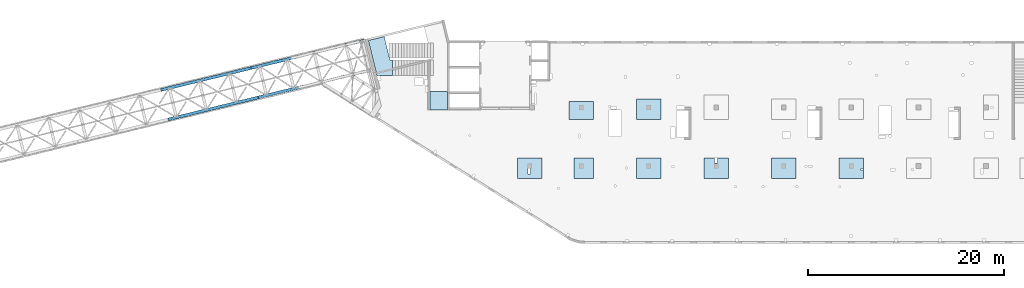
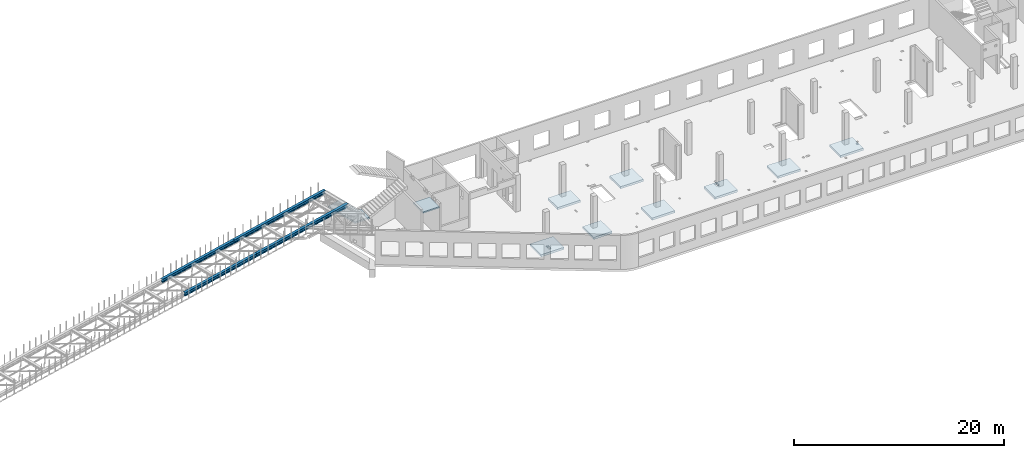
# One storey, part 13 of 66: 10 slabs, 4 beams.
"""IFC4 building model written with IfcOpenShell, lengths in millimetres."""

from ifc_helpers import new_model, entity, si_unit, converted_unit, derived_unit, direction, frame, origin, place, context, subcontext, project, spatial, indexed_curve, outline, extrude, material, type_object, element, save


model = new_model("IFC4")

# Units and contexts
model_context = context("Model", 3, precision=0.01, world=origin(), true_north=direction((6.12303176911189e-17, 1.0)))
plan_context = context("Plan", 3, precision=0.01, world=origin(), true_north=direction((6.12303176911189e-17, 1.0)))
body_context = subcontext(model_context, "Body", "Model", "MODEL_VIEW")
ifc_project = project(units=[si_unit("LENGTHUNIT", "METRE", prefix="MILLI"), si_unit("AREAUNIT", "SQUARE_METRE"), si_unit("VOLUMEUNIT", "CUBIC_METRE"), converted_unit("PLANEANGLEUNIT", "DEGREE", entity("IfcRatioMeasure", 0.0174532925199433), si_unit("PLANEANGLEUNIT", "RADIAN"), dimensions=[0, 0, 0, 0, 0, 0, 0]), si_unit("MASSUNIT", "GRAM", prefix="KILO"), derived_unit("MASSDENSITYUNIT", [(si_unit("MASSUNIT", "GRAM", prefix="KILO"), 1), (si_unit("LENGTHUNIT", "METRE"), -3)]), derived_unit("MOMENTOFINERTIAUNIT", [(si_unit("LENGTHUNIT", "METRE"), 4)]), si_unit("TIMEUNIT", "SECOND"), si_unit("FREQUENCYUNIT", "HERTZ"), si_unit("THERMODYNAMICTEMPERATUREUNIT", "DEGREE_CELSIUS"), derived_unit("THERMALTRANSMITTANCEUNIT", [(si_unit("MASSUNIT", "GRAM", prefix="KILO"), 1), (si_unit("THERMODYNAMICTEMPERATUREUNIT", "KELVIN"), -1), (si_unit("TIMEUNIT", "SECOND"), -3)]), derived_unit("VOLUMETRICFLOWRATEUNIT", [(si_unit("LENGTHUNIT", "METRE"), 3), (si_unit("TIMEUNIT", "SECOND"), -1)]), derived_unit("MASSFLOWRATEUNIT", [(si_unit("MASSUNIT", "GRAM", prefix="KILO"), 1), (si_unit("TIMEUNIT", "SECOND"), -1)]), derived_unit("ROTATIONALFREQUENCYUNIT", [(si_unit("TIMEUNIT", "SECOND"), -1)]), si_unit("ELECTRICCURRENTUNIT", "AMPERE"), si_unit("ELECTRICVOLTAGEUNIT", "VOLT"), si_unit("POWERUNIT", "WATT"), si_unit("FORCEUNIT", "NEWTON", prefix="KILO"), si_unit("ILLUMINANCEUNIT", "LUX"), si_unit("LUMINOUSFLUXUNIT", "LUMEN"), si_unit("LUMINOUSINTENSITYUNIT", "CANDELA"), derived_unit("USERDEFINED", [(si_unit("MASSUNIT", "GRAM", prefix="KILO"), -1), (si_unit("LENGTHUNIT", "METRE"), -2), (si_unit("TIMEUNIT", "SECOND"), 3), (si_unit("LUMINOUSFLUXUNIT", "LUMEN"), 1)]), derived_unit("LINEARVELOCITYUNIT", [(si_unit("LENGTHUNIT", "METRE"), 1), (si_unit("TIMEUNIT", "SECOND"), -1)]), si_unit("PRESSUREUNIT", "PASCAL"), derived_unit("USERDEFINED", [(si_unit("LENGTHUNIT", "METRE"), -2), (si_unit("MASSUNIT", "GRAM", prefix="KILO"), 1), (si_unit("TIMEUNIT", "SECOND"), -2)]), derived_unit("LINEARFORCEUNIT", [(si_unit("MASSUNIT", "GRAM", prefix="KILO"), 1), (si_unit("LENGTHUNIT", "METRE"), 1), (si_unit("TIMEUNIT", "SECOND"), -2), (si_unit("LENGTHUNIT", "METRE"), -1)]), derived_unit("PLANARFORCEUNIT", [(si_unit("MASSUNIT", "GRAM", prefix="KILO"), 1), (si_unit("LENGTHUNIT", "METRE"), 1), (si_unit("TIMEUNIT", "SECOND"), -2), (si_unit("LENGTHUNIT", "METRE"), -2)])], contexts=[model_context, plan_context])

# Site, building, storey
site_placement = place(None, origin())
site = spatial("IfcSite", under=ifc_project, at=site_placement, CompositionType="ELEMENT")
building_placement = place(site_placement, origin())
building = spatial("IfcBuilding", under=site, at=building_placement, CompositionType="ELEMENT")
storey_placement = place(building_placement, frame((0.0, 0.0, 19800.0)))
storey = spatial("IfcBuildingStorey", under=building, at=storey_placement, Name="06", CompositionType="ELEMENT", Elevation=19800.0)

# Beams
ifc_material_1 = material(Name="Metal painted (White)")
beam_type = type_object("IfcBeamType", PredefinedType="BEAM")
placement = place(storey_placement, origin())
element("IfcBeam", 1, at=placement, inside=storey, type_object=beam_type, material=ifc_material_1, ObjectType="Steel Beam", PredefinedType="BEAM", context=body_context, shape_type="SweptSolid", body=[
    extrude(outline(indexed_curve([(-195.999999999999, -150.000000000003), (-180.000000000002, -150.000000000003), (-180.000000000002, -27.750000000002), (-178.325349715245, -19.3309644879713), (-173.556349186105, -12.1936508138975), (-166.419035512031, -7.4246502847528), (-157.999999999999, -5.75000000000215), (158.000000000003, -5.75000000000215), (166.419035512027, -7.4246502847528), (173.556349186101, -12.1936508138975), (178.325349715249, -19.3309644879713), (180.000000000002, -27.750000000002), (180.000000000002, -150.000000000003), (195.999999999999, -150.000000000003), (195.999999999999, 149.999999999996), (180.000000000002, 149.999999999996), (180.000000000002, 27.7499999999947), (178.325349715249, 19.330964487967), (173.556349186101, 12.1936508138912), (166.419035512027, 7.42465028474967), (158.000000000003, 5.74999999999584), (-157.999999999999, 5.74999999999584), (-166.419035512031, 7.42465028474967), (-173.556349186105, 12.1936508138912), (-178.325349715245, 19.330964487967), (-179.999999999998, 27.7499999999999), (-180.000000000002, 149.999999999996), (-195.999999999999, 149.999999999996), (-195.999999999999, -150.000000000003)], self_intersect=False)), frame((-21068.66, 12465.87, 3912.0), z_axis=(0.971552058141469, 0.236826092990355, 0.0), x_axis=(0.0, 0.0, 1.0)), (0.0, 0.0, 1.0), 9479.99999999997),
])
element("IfcBeam", 2, at=placement, inside=storey, type_object=beam_type, material=ifc_material_1, ObjectType="Steel Beam", PredefinedType="BEAM", context=body_context, shape_type="SweptSolid", body=[
    extrude(outline(indexed_curve([(-195.999999999999, -150.0), (-180.000000000002, -150.0), (-180.000000000002, -27.7499999999994), (-178.325349715245, -19.3309644879692), (-173.556349186105, -12.1936508138954), (-166.419035512031, -7.42465028475019), (-157.999999999999, -5.75000000000056), (158.000000000003, -5.75000000000056), (166.419035512027, -7.42465028475019), (173.556349186101, -12.1936508138954), (178.325349715249, -19.3309644879692), (180.000000000002, -27.7499999999994), (180.000000000002, -150.0), (195.999999999999, -150.0), (195.999999999999, 150.0), (180.000000000002, 150.0), (180.000000000002, 27.7499999999994), (178.325349715249, 19.3309644879665), (173.556349186101, 12.1936508138933), (166.419035512027, 7.42465028475229), (158.000000000003, 5.74999999999794), (-157.999999999999, 5.75000000000005), (-166.419035512031, 7.42465028475229), (-173.556349186105, 12.1936508138954), (-178.325349715245, 19.3309644879713), (-179.999999999998, 27.7499999999994), (-180.000000000002, 150.0), (-195.999999999999, 150.0), (-195.999999999999, -150.0)], self_intersect=False)), frame((-11858.35, 14710.98, 3912.0), z_axis=(0.971552058141473, 0.236826092990339, 0.0), x_axis=(0.0, 0.0, 1.0)), (0.0, 0.0, 1.0), 11955.0),
])
element("IfcBeam", 3, at=placement, inside=storey, type_object=beam_type, material=ifc_material_1, ObjectType="Steel Beam", PredefinedType="BEAM", context=body_context, shape_type="SweptSolid", body=[
    extrude(outline(indexed_curve([(-195.999999999999, -150.000000000001), (-180.000000000002, -150.000000000001), (-180.000000000002, -27.7499999999999), (-178.325349715245, -19.3309644879691), (-173.556349186105, -12.1936508138954), (-166.419035512031, -7.4246502847528), (-157.999999999999, -5.75000000000005), (158.000000000003, -5.75000000000005), (166.419035512027, -7.4246502847528), (173.556349186101, -12.1936508138954), (178.325349715249, -19.3309644879691), (180.000000000002, -27.7499999999999), (180.000000000002, -150.000000000001), (195.999999999999, -150.000000000001), (195.999999999999, 149.999999999998), (180.000000000002, 149.999999999998), (180.000000000002, 27.7499999999968), (178.325349715249, 19.3309644879691), (173.556349186101, 12.1936508138933), (166.419035512027, 7.4246502847528), (158.000000000003, 5.74999999999794), (-157.999999999999, 5.74999999999794), (-166.419035512031, 7.42465028474967), (-173.556349186105, 12.1936508138912), (-178.325349715245, 19.330964487967), (-179.999999999998, 27.7499999999999), (-180.000000000002, 149.999999999998), (-195.999999999999, 149.999999999998), (-195.999999999999, -150.000000000001)], self_intersect=False)), frame((-21802.82, 15477.68, 3912.0), z_axis=(0.971552058141469, 0.236826092990355, 0.0), x_axis=(0.0, 0.0, 1.0)), (0.0, 0.0, 1.0), 9479.99999999997),
])
element("IfcBeam", 4, at=placement, inside=storey, type_object=beam_type, material=ifc_material_1, ObjectType="Steel Beam", PredefinedType="BEAM", context=body_context, shape_type="SweptSolid", body=[
    extrude(outline(indexed_curve([(-195.999999999999, -150.000000000007), (-180.000000000002, -150.000000000007), (-180.000000000002, -27.7500000000062), (-178.325349715245, -19.3309644879734), (-173.556349186105, -12.1936508139022), (-166.419035512031, -7.42465028475912), (-157.999999999999, -5.75000000000687), (158.000000000003, -5.75000000000687), (166.419035512027, -7.42465028475912), (173.556349186101, -12.1936508139022), (178.325349715249, -19.3309644879734), (180.000000000002, -27.7500000000062), (180.000000000002, -150.000000000007), (195.999999999999, -150.000000000007), (195.999999999999, 149.999999999993), (180.000000000002, 149.999999999993), (180.000000000002, 27.7499999999926), (178.325349715249, 19.3309644879623), (173.556349186101, 12.1936508138891), (166.419035512027, 7.42465028474547), (158.000000000003, 5.74999999999373), (-157.999999999999, 5.74999999999373), (-166.419035512031, 7.42465028474547), (-173.556349186105, 12.1936508138886), (-178.325349715245, 19.3309644879623), (-179.999999999998, 27.7499999999926), (-180.000000000002, 149.999999999993), (-195.999999999999, 149.999999999993), (-195.999999999999, -150.000000000007)], self_intersect=False)), frame((-12592.51, 17722.79, 3912.0), z_axis=(0.971552058141473, 0.236826092990339, 0.0), x_axis=(0.0, 0.0, 1.0)), (0.0, 0.0, 1.0), 11964.0),
])

# Slabs
ifc_material_2 = material()
slab_type_1 = type_object("IfcSlabType", Name=":ADSK_ 25_250", PredefinedType="FLOOR", material=ifc_material_2)
element("IfcSlab", 5, at=placement, inside=storey, type_object=slab_type_1, material=ifc_material_2, Name=":ADSK_ 25_250", ObjectType=":ADSK_ 25_250", PredefinedType="FLOOR", context=body_context, shape_type="SweptSolid", body=[
    extrude(outline(indexed_curve([(-1250.00044555664, -1049.99999999999), (1250.00044555664, -1049.99999999999), (1250.00044555664, 1049.99999999999), (-1250.00044555664, 1049.99999999999), (-1250.00044555664, -1049.99999999999)], self_intersect=False), holes=[indexed_curve([(-89.9998565673759, 49.999314856811), (-89.9998565673759, 609.999314856811), (160.000143432619, 609.999314856811), (160.000143432619, 49.999314856811), (-89.9998565673759, 49.999314856811)], self_intersect=False)]), frame((15900.0, 7500.0, -650.0), z_axis=(0.0, 0.0, 1.0), x_axis=(-1.0, 0.0, 0.0)), (0.0, 0.0, 1.0), 249.999999999999),
])
slab_type_2 = type_object("IfcSlabType", Name=":ADSK_ 25_250", PredefinedType="FLOOR", material=ifc_material_2)
element("IfcSlab", 6, at=placement, inside=storey, type_object=slab_type_2, material=ifc_material_2, Name=":ADSK_ 25_250", ObjectType=":ADSK_ 25_250", PredefinedType="FLOOR", context=body_context, shape_type="SweptSolid", body=[
    extrude(outline(indexed_curve([(-1050.0, -1000.0), (1050.0, -1000.0), (1050.0, 1000.0), (-1050.0, 1000.0), (-1050.0, -1000.0)], self_intersect=False)), frame((21420.0, 7500.0, -400.0), z_axis=(0.0, 0.0, -1.0), x_axis=(0.0, 1.0, 0.0)), (0.0, 0.0, 1.0), 249.999999999999),
])
slab_type_3 = type_object("IfcSlabType", Name=":ADSK_ 25_250", PredefinedType="FLOOR", material=ifc_material_2)
element("IfcSlab", 7, at=placement, inside=storey, type_object=slab_type_3, material=ifc_material_2, Name=":ADSK_ 25_250", ObjectType=":ADSK_ 25_250", PredefinedType="FLOOR", context=body_context, shape_type="SweptSolid", body=[
    extrude(outline(indexed_curve([(-1050.0, -1250.0), (1050.0, -1250.0), (1050.0, 1250.0), (-1050.0, 1250.0), (-1050.0, -1250.0)], self_intersect=False)), frame((28070.0, 7500.0, -400.0), z_axis=(0.0, 0.0, -1.0), x_axis=(0.0, 1.0, 0.0)), (0.0, 0.0, 1.0), 249.999999999999),
])
slab_type_4 = type_object("IfcSlabType", Name=":ADSK_ 25_250", PredefinedType="FLOOR", material=ifc_material_2)
element("IfcSlab", 8, at=placement, inside=storey, type_object=slab_type_4, material=ifc_material_2, Name=":ADSK_ 25_250", ObjectType=":ADSK_ 25_250", PredefinedType="FLOOR", context=body_context, shape_type="SweptSolid", body=[
    extrude(outline(indexed_curve([(-1250.0, -1050.0), (1250.0, -1050.0), (1250.0, 1050.0), (-1250.0, 1050.0), (-1250.0, -1050.0)], self_intersect=False), holes=[indexed_curve([(-140.000000000007, -1019.99999999999), (-140.000000000007, -489.999999999993), (189.999999999991, -489.999999999993), (189.999999999991, -1019.99999999999), (-140.000000000007, -1019.99999999999)], self_intersect=False)]), frame((34970.0, 7500.0, -650.0), z_axis=(0.0, 0.0, 1.0), x_axis=(-1.0, 0.0, 0.0)), (0.0, 0.0, 1.0), 249.999999999999),
])
slab_type_5 = type_object("IfcSlabType", Name=":ADSK_ 25_250", PredefinedType="FLOOR", material=ifc_material_2)
element("IfcSlab", 9, at=placement, inside=storey, type_object=slab_type_5, material=ifc_material_2, Name=":ADSK_ 25_250", ObjectType=":ADSK_ 25_250", PredefinedType="FLOOR", context=body_context, shape_type="SweptSolid", body=[
    extrude(outline(indexed_curve([(-1049.99999999999, -1250.0), (1049.99999999999, -1250.0), (1049.99999999999, 1250.0), (-1049.99999999999, 1250.0), (-1049.99999999999, -1250.0)], self_intersect=False)), frame((41870.0, 7500.0, -400.0), z_axis=(0.0, 0.0, -1.0), x_axis=(0.0, 1.0, 0.0)), (0.0, 0.0, 1.0), 249.999999999999),
])
slab_type_6 = type_object("IfcSlabType", Name=":ADSK_ 25_250", PredefinedType="FLOOR", material=ifc_material_2)
element("IfcSlab", 10, at=placement, inside=storey, type_object=slab_type_6, material=ifc_material_2, Name=":ADSK_ 25_250", ObjectType=":ADSK_ 25_250", PredefinedType="FLOOR", context=body_context, shape_type="SweptSolid", body=[
    extrude(outline(indexed_curve([(-1250.0, -1049.99999999999), (1250.0, -1049.99999999999), (1250.0, 1049.99999999999), (-1250.0, 1049.99999999999), (-1250.0, -1049.99999999999)], self_intersect=False), holes=[indexed_curve([(-1200.0, 49.999314856693), (-1200.0, 250.000000000009), (-1000.00000000001, 250.000000000009), (-1000.00000000001, 49.999314856693), (-1200.0, 49.999314856693)], self_intersect=False)]), frame((48770.0, 7500.0, -650.0), z_axis=(0.0, 0.0, 1.0), x_axis=(-1.0, 0.0, 0.0)), (0.0, 0.0, 1.0), 249.999999999999),
])
slab_type_7 = type_object("IfcSlabType", Name=":ADSK_ 25_250", PredefinedType="FLOOR", material=ifc_material_2)
element("IfcSlab", 11, at=placement, inside=storey, type_object=slab_type_7, material=ifc_material_2, Name=":ADSK_ 25_250", ObjectType=":ADSK_ 25_250", PredefinedType="FLOOR", context=body_context, shape_type="SweptSolid", body=[
    extrude(outline(indexed_curve([(-924.999999999987, -1249.9999420166), (924.999999999989, -1249.9999420166), (924.999999999989, 1249.9999420166), (-924.999999999987, 1249.9999420166), (-924.999999999987, -1249.9999420166)], self_intersect=False)), frame((21170.0, 13375.0, -400.0), z_axis=(0.0, 0.0, -1.0), x_axis=(0.0, 1.0, 0.0)), (0.0, 0.0, 1.0), 249.999999999999),
])
slab_type_8 = type_object("IfcSlabType", Name=":ADSK_ 25_250", PredefinedType="FLOOR", material=ifc_material_2)
element("IfcSlab", 12, at=placement, inside=storey, type_object=slab_type_8, material=ifc_material_2, Name=":ADSK_ 25_250", ObjectType=":ADSK_ 25_250", PredefinedType="FLOOR", context=body_context, shape_type="SweptSolid", body=[
    extrude(outline(indexed_curve([(-1050.0, -1250.0), (1050.0, -1250.0), (1050.0, 1250.0), (-1050.0, 1250.0), (-1050.0, -1250.0)], self_intersect=False)), frame((28070.0, 13500.0, -400.0), z_axis=(0.0, 0.0, -1.0), x_axis=(0.0, 1.0, 0.0)), (0.0, 0.0, 1.0), 249.999999999999),
])
slab_type_9 = type_object("IfcSlabType", Name=":ADSK_ 25_150", PredefinedType="FLOOR", material=ifc_material_2)
element("IfcSlab", 13, at=placement, inside=storey, type_object=slab_type_9, material=ifc_material_2, Name=":ADSK_ 25_150", ObjectType=":ADSK_ 25_150", PredefinedType="FLOOR", context=body_context, shape_type="SweptSolid", body=[
    extrude(outline(indexed_curve([(-925.000000000015, -900.000000000001), (925.000000000013, -900.000000000001), (925.000000000013, 900.000000000001), (-925.000000000015, 900.000000000001), (-925.000000000015, -900.000000000001)], self_intersect=False)), frame((6600.0, 14375.0, 3450.0), z_axis=(0.0, 0.0, -1.0), x_axis=(0.0, 1.0, 0.0)), (0.0, 0.0, 1.0), 150.000000000001),
])
slab_type_10 = type_object("IfcSlabType", Name=":ADSK_ 25_200", PredefinedType="FLOOR", material=ifc_material_2)
element("IfcSlab", 14, at=placement, inside=storey, type_object=slab_type_10, material=ifc_material_2, Name=":ADSK_ 25_200", ObjectType=":ADSK_ 25_200", PredefinedType="FLOOR", context=body_context, shape_type="SweptSolid", body=[
    extrude(outline(indexed_curve([(-858.595056963561, -1784.08926906496), (732.087175547623, -1784.08926906496), (1605.85136626625, 1800.428750483), (-16.6405708300142, 2195.92832577686), (-604.107857056731, -214.089269064963), (-858.595056963562, -214.089269064962), (-858.595056963561, -1784.08926906496)], self_intersect=False)), frame((1011.41, 18744.09, 2070.0), z_axis=(0.0, 0.0, -1.0), x_axis=(-1.0, 0.0, 0.0)), (0.0, 0.0, 1.0), 199.999999999998),
])

save(model, "model.ifc")
